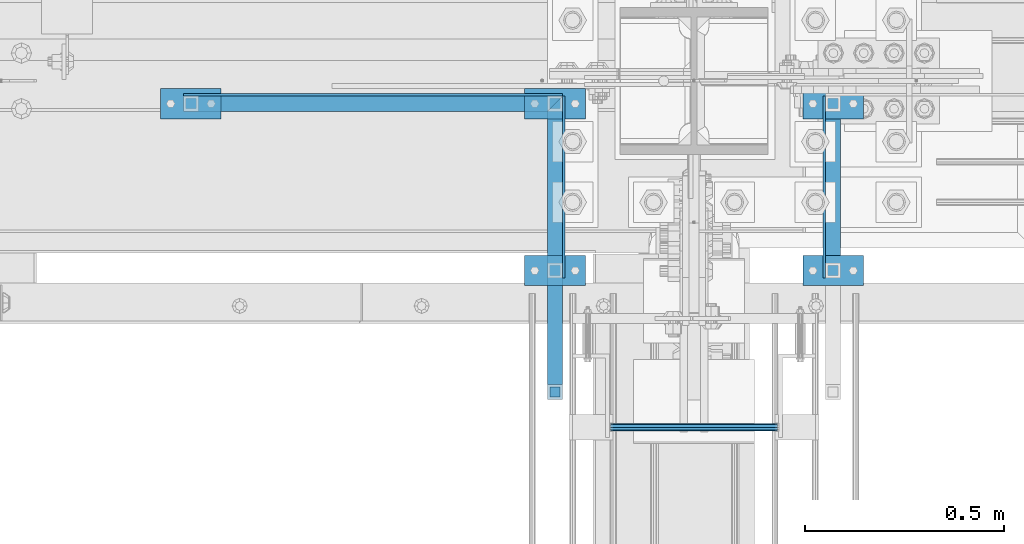
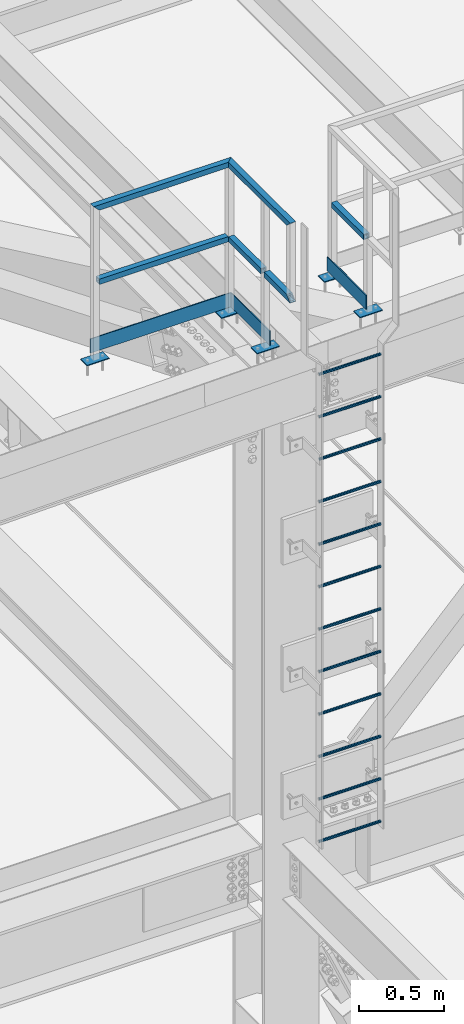
# One storey, part 2128 of 3843: 26 beams, 3 elements without a shape of their own.
"""IFC2X3 building model written with IfcOpenShell, lengths in millimetres."""

from ifc_helpers import new_model, si_unit, frame, origin_with_axes, place, context, subcontext, project, spatial, faceted_brep, material, type_object, element, aggregate, save


model = new_model("IFC2X3")

# Units and contexts
model_context = context("Model", 3, precision=1e-05, world=origin_with_axes())
body_context = subcontext(model_context, "Body", "Model", "MODEL_VIEW")
ifc_project = project(units=[si_unit("LENGTHUNIT", "METRE", prefix="MILLI"), si_unit("AREAUNIT", "SQUARE_METRE"), si_unit("VOLUMEUNIT", "CUBIC_METRE"), si_unit("MASSUNIT", "GRAM", prefix="KILO"), si_unit("TIMEUNIT", "SECOND"), si_unit("PLANEANGLEUNIT", "RADIAN"), si_unit("SOLIDANGLEUNIT", "STERADIAN"), si_unit("THERMODYNAMICTEMPERATUREUNIT", "DEGREE_CELSIUS"), si_unit("LUMINOUSINTENSITYUNIT", "LUMEN")], contexts=[model_context])

# Site, building, storey
site_placement = place(None, origin_with_axes())
site = spatial("IfcSite", under=ifc_project, at=site_placement, CompositionType="ELEMENT")
building_placement = place(site_placement, origin_with_axes())
building = spatial("IfcBuilding", under=site, at=building_placement, Name="Undefined", CompositionType="ELEMENT")
storey_placement = place(building_placement, origin_with_axes())
storey = spatial("IfcBuildingStorey", under=building, at=storey_placement, Name="Undefined", CompositionType="ELEMENT", Elevation=0.0)

# Assembly, beams
assembly_1_placement = place(storey_placement, origin_with_axes())
assembly_1 = element("IfcElementAssembly", 1, at=assembly_1_placement, inside=storey, Name="RAIL", AssemblyPlace="NOTDEFINED", PredefinedType="RIGID_FRAME")
ifc_material_1 = material()
beam_type_1 = type_object("IfcBeamType", Name="HSS1-1/2X1-1/2X1/4", PredefinedType="NOTDEFINED")
beam_1_placement = place(assembly_1_placement, frame((55581.550000765, 25558.75, 46837.6), z_axis=(0.0, 1.0, 0.0), x_axis=(-1.0, 0.0, 0.0)))
beam_1 = element("IfcBeam", 2, at=beam_1_placement, type_object=beam_type_1, material=ifc_material_1, Name="RAIL", ObjectType="HSS1-1/2X1-1/2X1/4", context=body_context, shape_type="Brep", body=[
    faceted_brep([(19.0499992350015, 12.6999993299978, -12.6999993299978), (19.0499992350015, -12.6999993299978, -12.6999993299978), (895.350000765007, -12.6999993299978, -12.6999993300014), (895.350000765007, 12.6999993299978, -12.6999993300014), (19.0499992350015, -12.6999993299978, 12.6999993299978), (895.350000765007, -12.6999993299978, 12.6999993300014), (19.0499992350015, 12.6999993299978, 12.6999993299978), (895.350000765007, 12.6999993299978, 12.6999993300014), (19.0499992350015, 19.0499992350015, -19.0499992350015), (19.0499992350015, 19.0499992350015, 19.0499992350015), (895.350000765007, 19.0499992350015, 19.0499992350015), (895.350000765007, 19.0499992350015, -19.0499992350015), (19.0499992350015, -19.0499992350015, 19.0499992350015), (895.350000765007, -19.0499992350015, 19.0499992350015), (19.0499992350015, -19.0499992350015, -19.0499992350015), (895.350000765007, -19.0499992350015, -19.0499992350015)], [[[0, 1, 2, 3]], [[1, 4, 5, 2]], [[4, 6, 7, 5]], [[6, 0, 3, 7]], [[8, 9, 10, 11]], [[9, 12, 13, 10]], [[12, 14, 15, 13]], [[14, 8, 11, 15]], [[13, 15, 11, 10], [5, 7, 3, 2]], [[14, 12, 9, 8], [6, 4, 1, 0]]]),
])
beam_2_placement = place(assembly_1_placement, frame((55581.550000765, 25558.75, 46837.6), z_axis=(-1.0, 0.0, 0.0), x_axis=(0.0, -1.0, 0.0)))
beam_2 = element("IfcBeam", 3, at=beam_2_placement, type_object=beam_type_1, material=ifc_material_1, Name="RAIL", ObjectType="HSS1-1/2X1-1/2X1/4", context=body_context, shape_type="Brep", body=[
    faceted_brep([(19.0499992350015, 12.6999993299978, -12.6999993299978), (19.0499992350015, -12.6999993299978, -12.6999993299978), (400.050000764713, -12.6999993299978, -12.6999993299978), (400.050000764713, 12.6999993299978, -12.6999993299978), (19.0499992350015, -12.6999993299978, 12.6999993299978), (400.050000764713, -12.6999993299978, 12.6999993299978), (19.0499992350015, 12.6999993299978, 12.6999993299978), (400.050000764713, 12.6999993299978, 12.6999993299978), (19.0499992350015, 19.0499992350015, -19.0499992350015), (19.0499992350015, 19.0499992350015, 19.0499992350015), (400.050000764713, 19.0499992350015, 19.0499992350015), (400.050000764713, 19.0499992350015, -19.0499992350015), (19.0499992350015, -19.0499992350015, 19.0499992350015), (400.050000764713, -19.0499992350015, 19.0499992350015), (19.0499992350015, -19.0499992350015, -19.0499992350015), (400.050000764713, -19.0499992350015, -19.0499992350015)], [[[0, 1, 2, 3]], [[1, 4, 5, 2]], [[4, 6, 7, 5]], [[6, 0, 3, 7]], [[8, 9, 10, 11]], [[9, 12, 13, 10]], [[12, 14, 15, 13]], [[14, 8, 11, 15]], [[13, 15, 11, 10], [5, 7, 3, 2]], [[14, 12, 9, 8], [6, 4, 1, 0]]]),
])
beam_3_placement = place(assembly_1_placement, frame((55581.550000765, 25139.6500000003, 46837.6), z_axis=(-1.0, 0.0, 0.0), x_axis=(0.0, -1.0, 0.0)))
beam_3 = element("IfcBeam", 4, at=beam_3_placement, type_object=beam_type_1, material=ifc_material_1, Name="RAIL", ObjectType="HSS1-1/2X1-1/2X1/4", context=body_context, shape_type="Brep", body=[
    faceted_brep([(19.0499992350015, 12.6999993299978, -12.6999993299978), (19.0499992350015, -12.6999993299978, -12.6999993299978), (317.499999330288, -12.6999993299978, -12.6999993299978), (292.100000670285, 12.6999993299978, -12.6999993299978), (19.0499992350015, -12.6999993299978, 12.6999993299978), (317.499999330288, -12.6999993299978, 12.6999993299978), (19.0499992350015, 12.6999993299978, 12.6999993299978), (292.100000670285, 12.6999993299978, 12.6999993299978), (19.0499992350015, 19.0499992350015, -19.0499992350015), (19.0499992350015, 19.0499992350015, 19.0499992350015), (285.750000765285, 19.0499992350015, 19.0499992350015), (285.750000765285, 19.0499992350015, -19.0499992350015), (19.0499992350015, -19.0499992350015, 19.0499992350015), (323.849999235288, -19.0499992350015, 19.0499992350015), (19.0499992350015, -19.0499992350015, -19.0499992350015), (323.849999235288, -19.0499992350015, -19.0499992350015)], [[[0, 1, 2, 3]], [[1, 4, 5, 2]], [[4, 6, 7, 5]], [[6, 0, 3, 7]], [[8, 9, 10, 11]], [[9, 12, 13, 10]], [[12, 14, 15, 13]], [[14, 8, 11, 15]], [[13, 15, 11, 10], [5, 7, 3, 2]], [[14, 12, 9, 8], [6, 4, 1, 0]]]),
])
beam_4_placement = place(assembly_1_placement, frame((55581.550000765, 25558.75, 47371.0), z_axis=(-1.0, 0.0, 0.0), x_axis=(0.0, -1.0, 0.0)))
beam_4 = element("IfcBeam", 5, at=beam_4_placement, type_object=beam_type_1, material=ifc_material_1, Name="RAIL", ObjectType="HSS1-1/2X1-1/2X1/4", context=body_context, shape_type="Brep", body=[
    faceted_brep([(-12.6999993309546, 12.6999993299978, -12.6999993299978), (-12.6999993309546, -12.6999993299978, -12.6999993299978), (711.20000067, -12.6999993299978, -12.6999993299978), (736.599999330003, 12.6999993299978, -12.6999993299978), (12.6999993290483, -12.6999993299978, 12.6999993299978), (711.20000067, -12.6999993299978, 12.6999993299978), (12.6999993290483, 12.6999993299978, 12.6999993299978), (736.599999330003, 12.6999993299978, 12.6999993299978), (-19.0499992359546, 19.0499992350015, -19.0499992350015), (19.0499992350015, 19.0499992350015, 19.0499992350015), (742.949999235003, 19.0499992350015, 19.0499992350015), (742.949999235003, 19.0499992350015, -19.0499992350015), (19.0499992350015, -19.0499992350015, 19.0499992350015), (704.850000765, -19.0499992350015, 19.0499992350015), (-19.0499992359546, -19.0499992350015, -19.0499992350015), (704.850000765, -19.0499992350015, -19.0499992350015)], [[[0, 1, 2, 3]], [[1, 4, 5, 2]], [[4, 6, 7, 5]], [[6, 0, 3, 7]], [[8, 9, 10, 11]], [[9, 12, 13, 10]], [[12, 14, 15, 13]], [[14, 8, 11, 15]], [[13, 15, 11, 10], [5, 7, 3, 2]], [[14, 12, 9, 8], [6, 4, 1, 0]]]),
])
beam_5_placement = place(assembly_1_placement, frame((55581.550000765, 25558.75, 47371.0), z_axis=(0.0, 1.0, 0.0), x_axis=(-1.0, 0.0, 0.0)))
beam_5 = element("IfcBeam", 6, at=beam_5_placement, type_object=beam_type_1, material=ifc_material_1, Name="RAIL", ObjectType="HSS1-1/2X1-1/2X1/4", context=body_context, shape_type="Brep", body=[
    faceted_brep([(12.6999993300196, 12.6999993299978, -12.6999993300014), (12.6999993300014, -12.6999993299978, -12.6999993300014), (901.700000670011, -12.6999993299978, -12.6999993300014), (927.099999330007, 12.6999993299978, -12.6999993300014), (-12.699999329976, -12.6999993299978, 12.6999993300014), (901.700000670011, -12.6999993299978, 12.6999993300014), (-12.6999993300014, 12.6999993299978, 12.6999993300014), (927.099999330007, 12.6999993299978, 12.6999993300014), (19.0499992350015, 19.0499992350015, -19.0499992350015), (-19.0499992350015, 19.0499992350015, 19.0499992350015), (933.44999923501, 19.0499992350015, 19.0499992350015), (933.44999923501, 19.0499992350015, -19.0499992350015), (-19.0499992349796, -19.0499992350015, 19.0499992350015), (895.350000765007, -19.0499992350015, 19.0499992350015), (19.0499992350015, -19.0499992350015, -19.0499992350015), (895.350000765007, -19.0499992350015, -19.0499992350015)], [[[0, 1, 2, 3]], [[1, 4, 5, 2]], [[4, 6, 7, 5]], [[6, 0, 3, 7]], [[8, 9, 10, 11]], [[9, 12, 13, 10]], [[12, 14, 15, 13]], [[14, 8, 11, 15]], [[13, 15, 11, 10], [5, 7, 3, 2]], [[14, 12, 9, 8], [6, 4, 1, 0]]]),
])

# Assembly, beam
assembly_2_placement = place(storey_placement, origin_with_axes())
assembly_2 = element("IfcElementAssembly", 7, at=assembly_2_placement, inside=storey, Name="RAIL", AssemblyPlace="NOTDEFINED", PredefinedType="RIGID_FRAME")
beam_6_placement = place(assembly_2_placement, frame((56280.049999235, 25558.75, 46837.6), z_axis=(1.0, 0.0, 0.0), x_axis=(0.0, -1.0, 0.0)))
beam_6 = element("IfcBeam", 8, at=beam_6_placement, type_object=beam_type_1, material=ifc_material_1, Name="RAIL", ObjectType="HSS1-1/2X1-1/2X1/4", context=body_context, shape_type="Brep", body=[
    faceted_brep([(19.0499992350015, 12.6999993299978, -12.6999993299978), (19.0499992350015, -12.6999993299978, -12.6999993299978), (400.050000764713, -12.6999993299978, -12.6999993299978), (400.050000764713, 12.6999993299978, -12.6999993299978), (19.0499992350015, -12.6999993299978, 12.6999993299978), (400.050000764713, -12.6999993299978, 12.6999993299978), (19.0499992350015, 12.6999993299978, 12.6999993299978), (400.050000764713, 12.6999993299978, 12.6999993299978), (19.0499992350015, 19.0499992350015, -19.0499992350015), (19.0499992350015, 19.0499992350015, 19.0499992350015), (400.050000764713, 19.0499992350015, 19.0499992350015), (400.050000764713, 19.0499992350015, -19.0499992350015), (19.0499992350015, -19.0499992350015, 19.0499992350015), (400.050000764713, -19.0499992350015, 19.0499992350015), (19.0499992350015, -19.0499992350015, -19.0499992350015), (400.050000764713, -19.0499992350015, -19.0499992350015)], [[[0, 1, 2, 3]], [[1, 4, 5, 2]], [[4, 6, 7, 5]], [[6, 0, 3, 7]], [[8, 9, 10, 11]], [[9, 12, 13, 10]], [[12, 14, 15, 13]], [[14, 8, 11, 15]], [[13, 15, 11, 10], [5, 7, 3, 2]], [[14, 12, 9, 8], [6, 4, 1, 0]]]),
])

# Beam
ifc_material_2 = material(Name="STEEL/A36")
beam_type_2 = type_object("IfcBeamType", PredefinedType="NOTDEFINED")
beam_7_placement = place(assembly_1_placement, frame((54590.950000765, 25558.75, 46280.6579856789), z_axis=(0.0, 1.0, 0.0), x_axis=(1.0, 0.0, 0.0)))
beam_7 = element("IfcBeam", 9, at=beam_7_placement, type_object=beam_type_2, material=ifc_material_2, context=body_context, shape_type="Brep", body=[
    faceted_brep([(0.0, 3.17500000000291, -38.0999999999985), (0.0, 3.17500000000291, 38.0999999999985), (152.400000000009, 3.17500000000291, 38.0999999999985), (152.400000000009, 3.17500000000291, -38.0999999999985), (0.0, -3.17500000000291, 38.0999999999985), (152.400000000009, -3.17500000000291, 38.0999999999985), (0.0, -3.17500000000291, -38.0999999999985), (152.400000000009, -3.17500000000291, -38.0999999999985)], [[[0, 1, 2, 3]], [[1, 4, 5, 2]], [[4, 6, 7, 5]], [[6, 0, 3, 7]], [[5, 7, 3, 2]], [[6, 4, 1, 0]]]),
])

beam_8_placement = place(assembly_1_placement, frame((55505.350000765, 25558.75, 46300.0037901441), z_axis=(0.0, 1.0, 0.0), x_axis=(1.0, 0.0, 0.0)))
beam_8 = element("IfcBeam", 10, at=beam_8_placement, type_object=beam_type_2, material=ifc_material_2, context=body_context, shape_type="Brep", body=[
    faceted_brep([(0.0, 3.17500000000291, -38.0999999999985), (0.0, 3.17500000000291, 38.0999999999985), (152.400000000009, 3.17500000000291, 38.0999999999985), (152.400000000009, 3.17500000000291, -38.0999999999985), (0.0, -3.17500000000291, 38.0999999999985), (152.400000000009, -3.17500000000291, 38.0999999999985), (0.0, -3.17500000000291, -38.0999999999985), (152.400000000009, -3.17500000000291, -38.0999999999985)], [[[0, 1, 2, 3]], [[1, 4, 5, 2]], [[4, 6, 7, 5]], [[6, 0, 3, 7]], [[5, 7, 3, 2]], [[6, 4, 1, 0]]]),
])

beam_9_placement = place(assembly_1_placement, frame((55505.3500007645, 25139.6500000003, 46300.0037901441), z_axis=(0.0, 1.0, 0.0), x_axis=(1.0, 0.0, 0.0)))
beam_9 = element("IfcBeam", 11, at=beam_9_placement, type_object=beam_type_2, material=ifc_material_2, context=body_context, shape_type="Brep", body=[
    faceted_brep([(0.0, 3.17500000000291, -38.0999999999985), (0.0, 3.17500000000291, 38.0999999999985), (152.400000000009, 3.17500000000291, 38.0999999999985), (152.400000000009, 3.17500000000291, -38.0999999999985), (0.0, -3.17500000000291, 38.0999999999985), (152.400000000009, -3.17500000000291, 38.0999999999985), (0.0, -3.17500000000291, -38.0999999999985), (152.400000000009, -3.17500000000291, -38.0999999999985)], [[[0, 1, 2, 3]], [[1, 4, 5, 2]], [[4, 6, 7, 5]], [[6, 0, 3, 7]], [[5, 7, 3, 2]], [[6, 4, 1, 0]]]),
])

beam_10_placement = place(assembly_2_placement, frame((56356.2499992355, 25139.6500000003, 46314.781836248), z_axis=(0.0, -1.0, 0.0), x_axis=(-1.0, 0.0, 0.0)))
beam_10 = element("IfcBeam", 12, at=beam_10_placement, type_object=beam_type_2, material=ifc_material_2, context=body_context, shape_type="Brep", body=[
    faceted_brep([(0.0, 3.17500000000291, -38.0999999999985), (0.0, 3.17500000000291, 38.0999999999985), (152.400000000009, 3.17500000000291, 38.0999999999985), (152.400000000009, 3.17500000000291, -38.0999999999985), (0.0, -3.17500000000291, 38.0999999999985), (152.400000000009, -3.17500000000291, 38.0999999999985), (0.0, -3.17500000000291, -38.0999999999985), (152.400000000009, -3.17500000000291, -38.0999999999985)], [[[0, 1, 2, 3]], [[1, 4, 5, 2]], [[4, 6, 7, 5]], [[6, 0, 3, 7]], [[5, 7, 3, 2]], [[6, 4, 1, 0]]]),
])

beam_11_placement = place(assembly_2_placement, frame((56356.249999235, 25558.75, 46314.781836248), z_axis=(0.0, -1.0, 0.0), x_axis=(-1.0, 0.0, 0.0)))
beam_11 = element("IfcBeam", 13, at=beam_11_placement, type_object=beam_type_2, material=ifc_material_2, context=body_context, shape_type="Brep", body=[
    faceted_brep([(0.0, 3.17500000000291, -38.0999999999985), (0.0, 3.17500000000291, 38.0999999999985), (152.400000000009, 3.17500000000291, 38.0999999999985), (152.400000000009, 3.17500000000291, -38.0999999999985), (0.0, -3.17500000000291, 38.0999999999985), (152.400000000009, -3.17500000000291, 38.0999999999985), (0.0, -3.17500000000291, -38.0999999999985), (152.400000000009, -3.17500000000291, -38.0999999999985)], [[[0, 1, 2, 3]], [[1, 4, 5, 2]], [[4, 6, 7, 5]], [[6, 0, 3, 7]], [[5, 7, 3, 2]], [[6, 4, 1, 0]]]),
])

# Assembly, beams
assembly_3_placement = place(storey_placement, origin_with_axes())
assembly_3 = element("IfcElementAssembly", 14, at=assembly_3_placement, inside=storey, AssemblyPlace="NOTDEFINED", PredefinedType="RIGID_FRAME")
ifc_material_3 = material(Name="STEEL/A572-50")
beam_type_3 = type_object("IfcBeamType", PredefinedType="NOTDEFINED")
beam_12_placement = place(assembly_3_placement, frame((55721.2500000005, 24745.9500000003, 42941.875), z_axis=(0.0, 1.0, 0.0), x_axis=(1.0, 0.0, 0.0)))
beam_12 = element("IfcBeam", 15, at=beam_12_placement, type_object=beam_type_3, material=ifc_material_3, Name="RUNG", context=body_context, shape_type="Brep", body=[
    faceted_brep([(0.0, -9.52500000000146, 0.0), (0.0, -6.73519209080405, -6.73519209079677), (419.100000000006, -6.73519209080405, -6.73519209079677), (419.100000000006, -9.52500000000146, 0.0), (2.95075507493764e-12, 2.91322521661641e-12, -9.52499961853027), (419.100000000006, 0.0, -9.52499999999418), (0.0, 6.73519209080405, -6.73519209079677), (419.100000000006, 6.73519209080405, -6.73519209079677), (0.0, 9.52500000000146, 0.0), (419.100000000006, 9.52500000000146, 0.0), (0.0, 6.73519209080405, 6.73519209079677), (419.100000000006, 6.73519209080405, 6.73519209079677), (-9.87109982941227e-13, 2.91322521661641e-12, 9.52499961853027), (419.100000000006, 0.0, 9.52499999999418), (0.0, -6.73519209080405, 6.73519209079677), (419.100000000006, -6.73519209080405, 6.73519209079677)], [[[0, 1, 2, 3]], [[1, 4, 5, 2]], [[4, 6, 7, 5]], [[6, 8, 9, 7]], [[8, 10, 11, 9]], [[10, 12, 13, 11]], [[12, 14, 15, 13]], [[14, 0, 3, 15]], [[5, 7, 9, 11, 13, 15, 3, 2]], [[14, 12, 10, 8, 6, 4, 1, 0]]]),
])
beam_13_placement = place(assembly_3_placement, frame((55721.2500000005, 24745.9500000003, 43246.675), z_axis=(0.0, 1.0, 0.0), x_axis=(1.0, 0.0, 0.0)))
beam_13 = element("IfcBeam", 16, at=beam_13_placement, type_object=beam_type_3, material=ifc_material_3, Name="RUNG", context=body_context, shape_type="Brep", body=[
    faceted_brep([(0.0, -9.52500000000146, 0.0), (0.0, -6.73519209080405, -6.73519209079677), (419.100000000006, -6.73519209080405, -6.73519209079677), (419.100000000006, -9.52500000000146, 0.0), (2.95075507493764e-12, 2.91322521661641e-12, -9.52499961853027), (419.100000000006, 0.0, -9.52499999999418), (0.0, 6.73519209080405, -6.73519209079677), (419.100000000006, 6.73519209080405, -6.73519209079677), (0.0, 9.52500000000146, 0.0), (419.100000000006, 9.52500000000146, 0.0), (0.0, 6.73519209080405, 6.73519209079677), (419.100000000006, 6.73519209080405, 6.73519209079677), (-9.87109982941227e-13, 2.91322521661641e-12, 9.52499961853027), (419.100000000006, 0.0, 9.52499999999418), (0.0, -6.73519209080405, 6.73519209079677), (419.100000000006, -6.73519209080405, 6.73519209079677)], [[[0, 1, 2, 3]], [[1, 4, 5, 2]], [[4, 6, 7, 5]], [[6, 8, 9, 7]], [[8, 10, 11, 9]], [[10, 12, 13, 11]], [[12, 14, 15, 13]], [[14, 0, 3, 15]], [[5, 7, 9, 11, 13, 15, 3, 2]], [[14, 12, 10, 8, 6, 4, 1, 0]]]),
])
beam_14_placement = place(assembly_3_placement, frame((55721.2500000005, 24745.9500000003, 43551.475), z_axis=(0.0, 1.0, 0.0), x_axis=(1.0, 0.0, 0.0)))
beam_14 = element("IfcBeam", 17, at=beam_14_placement, type_object=beam_type_3, material=ifc_material_3, Name="RUNG", context=body_context, shape_type="Brep", body=[
    faceted_brep([(0.0, -9.52500000000146, 0.0), (0.0, -6.73519209080405, -6.73519209079677), (419.100000000006, -6.73519209080405, -6.73519209079677), (419.100000000006, -9.52500000000146, 0.0), (2.95075507493764e-12, 2.91322521661641e-12, -9.52499961853027), (419.100000000006, 0.0, -9.52499999999418), (0.0, 6.73519209080405, -6.73519209079677), (419.100000000006, 6.73519209080405, -6.73519209079677), (0.0, 9.52500000000146, 0.0), (419.100000000006, 9.52500000000146, 0.0), (0.0, 6.73519209080405, 6.73519209079677), (419.100000000006, 6.73519209080405, 6.73519209079677), (-9.87109982941227e-13, 2.91322521661641e-12, 9.52499961853027), (419.100000000006, 0.0, 9.52499999999418), (0.0, -6.73519209080405, 6.73519209079677), (419.100000000006, -6.73519209080405, 6.73519209079677)], [[[0, 1, 2, 3]], [[1, 4, 5, 2]], [[4, 6, 7, 5]], [[6, 8, 9, 7]], [[8, 10, 11, 9]], [[10, 12, 13, 11]], [[12, 14, 15, 13]], [[14, 0, 3, 15]], [[5, 7, 9, 11, 13, 15, 3, 2]], [[14, 12, 10, 8, 6, 4, 1, 0]]]),
])
beam_15_placement = place(assembly_3_placement, frame((55721.2500000005, 24745.9500000003, 43856.275), z_axis=(0.0, 1.0, 0.0), x_axis=(1.0, 0.0, 0.0)))
beam_15 = element("IfcBeam", 18, at=beam_15_placement, type_object=beam_type_3, material=ifc_material_3, Name="RUNG", context=body_context, shape_type="Brep", body=[
    faceted_brep([(0.0, -9.52500000000146, 0.0), (0.0, -6.73519209080405, -6.73519209079677), (419.100000000006, -6.73519209080405, -6.73519209079677), (419.100000000006, -9.52500000000146, 0.0), (2.95075507493764e-12, 2.91322521661641e-12, -9.52499961853027), (419.100000000006, 0.0, -9.52499999999418), (0.0, 6.73519209080405, -6.73519209079677), (419.100000000006, 6.73519209080405, -6.73519209079677), (0.0, 9.52500000000146, 0.0), (419.100000000006, 9.52500000000146, 0.0), (0.0, 6.73519209080405, 6.73519209079677), (419.100000000006, 6.73519209080405, 6.73519209079677), (-9.87109982941227e-13, 2.91322521661641e-12, 9.52499961853027), (419.100000000006, 0.0, 9.52499999999418), (0.0, -6.73519209080405, 6.73519209079677), (419.100000000006, -6.73519209080405, 6.73519209079677)], [[[0, 1, 2, 3]], [[1, 4, 5, 2]], [[4, 6, 7, 5]], [[6, 8, 9, 7]], [[8, 10, 11, 9]], [[10, 12, 13, 11]], [[12, 14, 15, 13]], [[14, 0, 3, 15]], [[5, 7, 9, 11, 13, 15, 3, 2]], [[14, 12, 10, 8, 6, 4, 1, 0]]]),
])
beam_16_placement = place(assembly_3_placement, frame((55721.2500000005, 24745.9500000003, 44161.075), z_axis=(0.0, 1.0, 0.0), x_axis=(1.0, 0.0, 0.0)))
beam_16 = element("IfcBeam", 19, at=beam_16_placement, type_object=beam_type_3, material=ifc_material_3, Name="RUNG", context=body_context, shape_type="Brep", body=[
    faceted_brep([(0.0, -9.52500000000146, 0.0), (0.0, -6.73519209080405, -6.73519209079677), (419.100000000006, -6.73519209080405, -6.73519209079677), (419.100000000006, -9.52500000000146, 0.0), (2.95075507493764e-12, 2.91322521661641e-12, -9.52499961853027), (419.100000000006, 0.0, -9.52499999999418), (0.0, 6.73519209080405, -6.73519209079677), (419.100000000006, 6.73519209080405, -6.73519209079677), (0.0, 9.52500000000146, 0.0), (419.100000000006, 9.52500000000146, 0.0), (0.0, 6.73519209080405, 6.73519209079677), (419.100000000006, 6.73519209080405, 6.73519209079677), (-9.87109982941227e-13, 2.91322521661641e-12, 9.52499961853027), (419.100000000006, 0.0, 9.52499999999418), (0.0, -6.73519209080405, 6.73519209079677), (419.100000000006, -6.73519209080405, 6.73519209079677)], [[[0, 1, 2, 3]], [[1, 4, 5, 2]], [[4, 6, 7, 5]], [[6, 8, 9, 7]], [[8, 10, 11, 9]], [[10, 12, 13, 11]], [[12, 14, 15, 13]], [[14, 0, 3, 15]], [[5, 7, 9, 11, 13, 15, 3, 2]], [[14, 12, 10, 8, 6, 4, 1, 0]]]),
])
beam_17_placement = place(assembly_3_placement, frame((55721.2500000005, 24745.9500000003, 44465.875), z_axis=(0.0, 1.0, 0.0), x_axis=(1.0, 0.0, 0.0)))
beam_17 = element("IfcBeam", 20, at=beam_17_placement, type_object=beam_type_3, material=ifc_material_3, Name="RUNG", context=body_context, shape_type="Brep", body=[
    faceted_brep([(0.0, -9.52500000000146, 0.0), (0.0, -6.73519209080405, -6.73519209079677), (419.100000000006, -6.73519209080405, -6.73519209079677), (419.100000000006, -9.52500000000146, 0.0), (2.95075507493764e-12, 2.91322521661641e-12, -9.52499961853027), (419.100000000006, 0.0, -9.52499999999418), (0.0, 6.73519209080405, -6.73519209079677), (419.100000000006, 6.73519209080405, -6.73519209079677), (0.0, 9.52500000000146, 0.0), (419.100000000006, 9.52500000000146, 0.0), (0.0, 6.73519209080405, 6.73519209079677), (419.100000000006, 6.73519209080405, 6.73519209079677), (-9.87109982941227e-13, 2.91322521661641e-12, 9.52499961853027), (419.100000000006, 0.0, 9.52499999999418), (0.0, -6.73519209080405, 6.73519209079677), (419.100000000006, -6.73519209080405, 6.73519209079677)], [[[0, 1, 2, 3]], [[1, 4, 5, 2]], [[4, 6, 7, 5]], [[6, 8, 9, 7]], [[8, 10, 11, 9]], [[10, 12, 13, 11]], [[12, 14, 15, 13]], [[14, 0, 3, 15]], [[5, 7, 9, 11, 13, 15, 3, 2]], [[14, 12, 10, 8, 6, 4, 1, 0]]]),
])
beam_18_placement = place(assembly_3_placement, frame((55721.2500000005, 24745.9500000003, 44770.675), z_axis=(0.0, 1.0, 0.0), x_axis=(1.0, 0.0, 0.0)))
beam_18 = element("IfcBeam", 21, at=beam_18_placement, type_object=beam_type_3, material=ifc_material_3, Name="RUNG", context=body_context, shape_type="Brep", body=[
    faceted_brep([(0.0, -9.52500000000146, 0.0), (0.0, -6.73519209080405, -6.73519209079677), (419.100000000006, -6.73519209080405, -6.73519209079677), (419.100000000006, -9.52500000000146, 0.0), (2.95075507493764e-12, 2.91322521661641e-12, -9.52499961853027), (419.100000000006, 0.0, -9.52499999999418), (0.0, 6.73519209080405, -6.73519209079677), (419.100000000006, 6.73519209080405, -6.73519209079677), (0.0, 9.52500000000146, 0.0), (419.100000000006, 9.52500000000146, 0.0), (0.0, 6.73519209080405, 6.73519209079677), (419.100000000006, 6.73519209080405, 6.73519209079677), (-9.87109982941227e-13, 2.91322521661641e-12, 9.52499961853027), (419.100000000006, 0.0, 9.52499999999418), (0.0, -6.73519209080405, 6.73519209079677), (419.100000000006, -6.73519209080405, 6.73519209079677)], [[[0, 1, 2, 3]], [[1, 4, 5, 2]], [[4, 6, 7, 5]], [[6, 8, 9, 7]], [[8, 10, 11, 9]], [[10, 12, 13, 11]], [[12, 14, 15, 13]], [[14, 0, 3, 15]], [[5, 7, 9, 11, 13, 15, 3, 2]], [[14, 12, 10, 8, 6, 4, 1, 0]]]),
])
beam_19_placement = place(assembly_3_placement, frame((55721.2500000005, 24745.9500000003, 45075.475), z_axis=(0.0, 1.0, 0.0), x_axis=(1.0, 0.0, 0.0)))
beam_19 = element("IfcBeam", 22, at=beam_19_placement, type_object=beam_type_3, material=ifc_material_3, Name="RUNG", context=body_context, shape_type="Brep", body=[
    faceted_brep([(0.0, -9.52500000000146, 0.0), (0.0, -6.73519209080405, -6.73519209079677), (419.100000000006, -6.73519209080405, -6.73519209079677), (419.100000000006, -9.52500000000146, 0.0), (2.95075507493764e-12, 2.91322521661641e-12, -9.52499961853027), (419.100000000006, 0.0, -9.52499999999418), (0.0, 6.73519209080405, -6.73519209079677), (419.100000000006, 6.73519209080405, -6.73519209079677), (0.0, 9.52500000000146, 0.0), (419.100000000006, 9.52500000000146, 0.0), (0.0, 6.73519209080405, 6.73519209079677), (419.100000000006, 6.73519209080405, 6.73519209079677), (-9.87109982941227e-13, 2.91322521661641e-12, 9.52499961853027), (419.100000000006, 0.0, 9.52499999999418), (0.0, -6.73519209080405, 6.73519209079677), (419.100000000006, -6.73519209080405, 6.73519209079677)], [[[0, 1, 2, 3]], [[1, 4, 5, 2]], [[4, 6, 7, 5]], [[6, 8, 9, 7]], [[8, 10, 11, 9]], [[10, 12, 13, 11]], [[12, 14, 15, 13]], [[14, 0, 3, 15]], [[5, 7, 9, 11, 13, 15, 3, 2]], [[14, 12, 10, 8, 6, 4, 1, 0]]]),
])
beam_20_placement = place(assembly_3_placement, frame((55721.2500000005, 24745.9500000003, 45380.275), z_axis=(0.0, 1.0, 0.0), x_axis=(1.0, 0.0, 0.0)))
beam_20 = element("IfcBeam", 23, at=beam_20_placement, type_object=beam_type_3, material=ifc_material_3, Name="RUNG", context=body_context, shape_type="Brep", body=[
    faceted_brep([(0.0, -9.52500000000146, 0.0), (0.0, -6.73519209080405, -6.73519209079677), (419.100000000006, -6.73519209080405, -6.73519209079677), (419.100000000006, -9.52500000000146, 0.0), (2.95075507493764e-12, 2.91322521661641e-12, -9.52499961853027), (419.100000000006, 0.0, -9.52499999999418), (0.0, 6.73519209080405, -6.73519209079677), (419.100000000006, 6.73519209080405, -6.73519209079677), (0.0, 9.52500000000146, 0.0), (419.100000000006, 9.52500000000146, 0.0), (0.0, 6.73519209080405, 6.73519209079677), (419.100000000006, 6.73519209080405, 6.73519209079677), (-9.87109982941227e-13, 2.91322521661641e-12, 9.52499961853027), (419.100000000006, 0.0, 9.52499999999418), (0.0, -6.73519209080405, 6.73519209079677), (419.100000000006, -6.73519209080405, 6.73519209079677)], [[[0, 1, 2, 3]], [[1, 4, 5, 2]], [[4, 6, 7, 5]], [[6, 8, 9, 7]], [[8, 10, 11, 9]], [[10, 12, 13, 11]], [[12, 14, 15, 13]], [[14, 0, 3, 15]], [[5, 7, 9, 11, 13, 15, 3, 2]], [[14, 12, 10, 8, 6, 4, 1, 0]]]),
])
beam_21_placement = place(assembly_3_placement, frame((55721.2500000005, 24745.9500000003, 45685.075), z_axis=(0.0, 1.0, 0.0), x_axis=(1.0, 0.0, 0.0)))
beam_21 = element("IfcBeam", 24, at=beam_21_placement, type_object=beam_type_3, material=ifc_material_3, Name="RUNG", context=body_context, shape_type="Brep", body=[
    faceted_brep([(0.0, -9.52500000000146, 0.0), (0.0, -6.73519209080405, -6.73519209079677), (419.100000000006, -6.73519209080405, -6.73519209079677), (419.100000000006, -9.52500000000146, 0.0), (2.95075507493764e-12, 2.91322521661641e-12, -9.52499961853027), (419.100000000006, 0.0, -9.52499999999418), (0.0, 6.73519209080405, -6.73519209079677), (419.100000000006, 6.73519209080405, -6.73519209079677), (0.0, 9.52500000000146, 0.0), (419.100000000006, 9.52500000000146, 0.0), (0.0, 6.73519209080405, 6.73519209079677), (419.100000000006, 6.73519209080405, 6.73519209079677), (-9.87109982941227e-13, 2.91322521661641e-12, 9.52499961853027), (419.100000000006, 0.0, 9.52499999999418), (0.0, -6.73519209080405, 6.73519209079677), (419.100000000006, -6.73519209080405, 6.73519209079677)], [[[0, 1, 2, 3]], [[1, 4, 5, 2]], [[4, 6, 7, 5]], [[6, 8, 9, 7]], [[8, 10, 11, 9]], [[10, 12, 13, 11]], [[12, 14, 15, 13]], [[14, 0, 3, 15]], [[5, 7, 9, 11, 13, 15, 3, 2]], [[14, 12, 10, 8, 6, 4, 1, 0]]]),
])
beam_22_placement = place(assembly_3_placement, frame((55721.2500000005, 24745.9500000003, 45989.875), z_axis=(0.0, 1.0, 0.0), x_axis=(1.0, 0.0, 0.0)))
beam_22 = element("IfcBeam", 25, at=beam_22_placement, type_object=beam_type_3, material=ifc_material_3, Name="RUNG", context=body_context, shape_type="Brep", body=[
    faceted_brep([(0.0, -9.52500000000146, 0.0), (0.0, -6.73519209080405, -6.73519209079677), (419.100000000006, -6.73519209080405, -6.73519209079677), (419.100000000006, -9.52500000000146, 0.0), (2.95075507493764e-12, 2.91322521661641e-12, -9.52499961853027), (419.100000000006, 0.0, -9.52499999999418), (0.0, 6.73519209080405, -6.73519209079677), (419.100000000006, 6.73519209080405, -6.73519209079677), (0.0, 9.52500000000146, 0.0), (419.100000000006, 9.52500000000146, 0.0), (0.0, 6.73519209080405, 6.73519209079677), (419.100000000006, 6.73519209080405, 6.73519209079677), (-9.87109982941227e-13, 2.91322521661641e-12, 9.52499961853027), (419.100000000006, 0.0, 9.52499999999418), (0.0, -6.73519209080405, 6.73519209079677), (419.100000000006, -6.73519209080405, 6.73519209079677)], [[[0, 1, 2, 3]], [[1, 4, 5, 2]], [[4, 6, 7, 5]], [[6, 8, 9, 7]], [[8, 10, 11, 9]], [[10, 12, 13, 11]], [[12, 14, 15, 13]], [[14, 0, 3, 15]], [[5, 7, 9, 11, 13, 15, 3, 2]], [[14, 12, 10, 8, 6, 4, 1, 0]]]),
])
beam_23_placement = place(assembly_3_placement, frame((55721.2500000005, 24745.9500000003, 46294.675), z_axis=(0.0, 1.0, 0.0), x_axis=(1.0, 0.0, 0.0)))
beam_23 = element("IfcBeam", 26, at=beam_23_placement, type_object=beam_type_3, material=ifc_material_3, Name="RUNG", context=body_context, shape_type="Brep", body=[
    faceted_brep([(0.0, -9.52500000000146, 0.0), (0.0, -6.73519209080405, -6.73519209079677), (419.100000000006, -6.73519209080405, -6.73519209079677), (419.100000000006, -9.52500000000146, 0.0), (2.95075507493764e-12, 2.91322521661641e-12, -9.52499961853027), (419.100000000006, 0.0, -9.52499999999418), (0.0, 6.73519209080405, -6.73519209079677), (419.100000000006, 6.73519209080405, -6.73519209079677), (0.0, 9.52500000000146, 0.0), (419.100000000006, 9.52500000000146, 0.0), (0.0, 6.73519209080405, 6.73519209079677), (419.100000000006, 6.73519209080405, 6.73519209079677), (-9.87109982941227e-13, 2.91322521661641e-12, 9.52499961853027), (419.100000000006, 0.0, 9.52499999999418), (0.0, -6.73519209080405, 6.73519209079677), (419.100000000006, -6.73519209080405, 6.73519209079677)], [[[0, 1, 2, 3]], [[1, 4, 5, 2]], [[4, 6, 7, 5]], [[6, 8, 9, 7]], [[8, 10, 11, 9]], [[10, 12, 13, 11]], [[12, 14, 15, 13]], [[14, 0, 3, 15]], [[5, 7, 9, 11, 13, 15, 3, 2]], [[14, 12, 10, 8, 6, 4, 1, 0]]]),
])
aggregate(assembly_3, [beam_12, beam_13, beam_14, beam_15, beam_16, beam_17, beam_18, beam_19, beam_20, beam_21, beam_22, beam_23])

# Beam
beam_type_4 = type_object("IfcBeamType", PredefinedType="NOTDEFINED")
beam_24_placement = place(assembly_1_placement, frame((55600.5999992392, 25580.974999235, 46366.6787901441), z_axis=(0.0, 0.0, 1.0), x_axis=(-1.0, 0.0, 0.0)))
beam_24 = element("IfcBeam", 27, at=beam_24_placement, type_object=beam_type_4, material=ifc_material_2, Name="TOE_PLATE", context=body_context, shape_type="Brep", body=[
    faceted_brep([(0.0, 3.17500000000291, -50.8000000000029), (0.0, 3.17500000000291, 50.8000000000029), (952.499998469975, 3.17499999999927, 50.8000000000029), (952.499998469975, 3.17499999999927, -50.8000000000029), (0.0, -3.17500000000291, 50.8000000000029), (952.499998469975, -3.17499999999927, 50.8000000000029), (0.0, -3.17500000000291, -50.8000000000029), (952.499998469975, -3.17499999999927, -50.8000000000029)], [[[0, 1, 2, 3]], [[1, 4, 5, 2]], [[4, 6, 7, 5]], [[6, 0, 3, 7]], [[5, 7, 3, 2]], [[6, 4, 1, 0]]]),
])

beam_25_placement = place(assembly_1_placement, frame((55603.7749992391, 25120.6000007653, 46366.6787901441), z_axis=(0.0, 0.0, 1.0), x_axis=(0.0, 1.0, 0.0)))
beam_25 = element("IfcBeam", 28, at=beam_25_placement, type_object=beam_type_4, material=ifc_material_2, Name="TOE_PLATE", context=body_context, shape_type="Brep", body=[
    faceted_brep([(0.0, 3.17500000000291, -50.8000000000029), (0.0, 3.17500000000291, 50.8000000000029), (457.199998469714, 3.17500000000291, 50.8000000000029), (457.199998469714, 3.17500000000291, -50.8000000000029), (0.0, -3.17500000000291, 50.8000000000029), (457.199998469714, -3.17500000000291, 50.8000000000029), (0.0, -3.17500000000291, -50.8000000000029), (457.199998469714, -3.17500000000291, -50.8000000000029)], [[[0, 1, 2, 3]], [[1, 4, 5, 2]], [[4, 6, 7, 5]], [[6, 0, 3, 7]], [[5, 7, 3, 2]], [[6, 4, 1, 0]]]),
])

aggregate(assembly_1, [beam_24, beam_25, beam_7, beam_8, beam_9, beam_1, beam_2, beam_3, beam_4, beam_5])

beam_26_placement = place(assembly_2_placement, frame((56257.825, 25120.6000007653, 46394.156836248), z_axis=(0.0, 0.0, 1.0), x_axis=(0.0, 1.0, 0.0)))
beam_26 = element("IfcBeam", 29, at=beam_26_placement, type_object=beam_type_4, material=ifc_material_2, Name="TOE_PLATE", context=body_context, shape_type="Brep", body=[
    faceted_brep([(0.0, 3.17500000000291, -50.8000000000029), (0.0, 3.17500000000291, 50.8000000000029), (457.199998469714, 3.17500000000291, 50.8000000000029), (457.199998469714, 3.17500000000291, -50.8000000000029), (0.0, -3.17500000000291, 50.8000000000029), (457.199998469714, -3.17500000000291, 50.8000000000029), (0.0, -3.17500000000291, -50.8000000000029), (457.199998469714, -3.17500000000291, -50.8000000000029)], [[[0, 1, 2, 3]], [[1, 4, 5, 2]], [[4, 6, 7, 5]], [[6, 0, 3, 7]], [[5, 7, 3, 2]], [[6, 4, 1, 0]]]),
])

aggregate(assembly_2, [beam_26, beam_10, beam_11, beam_6])

save(model, "model.ifc")
